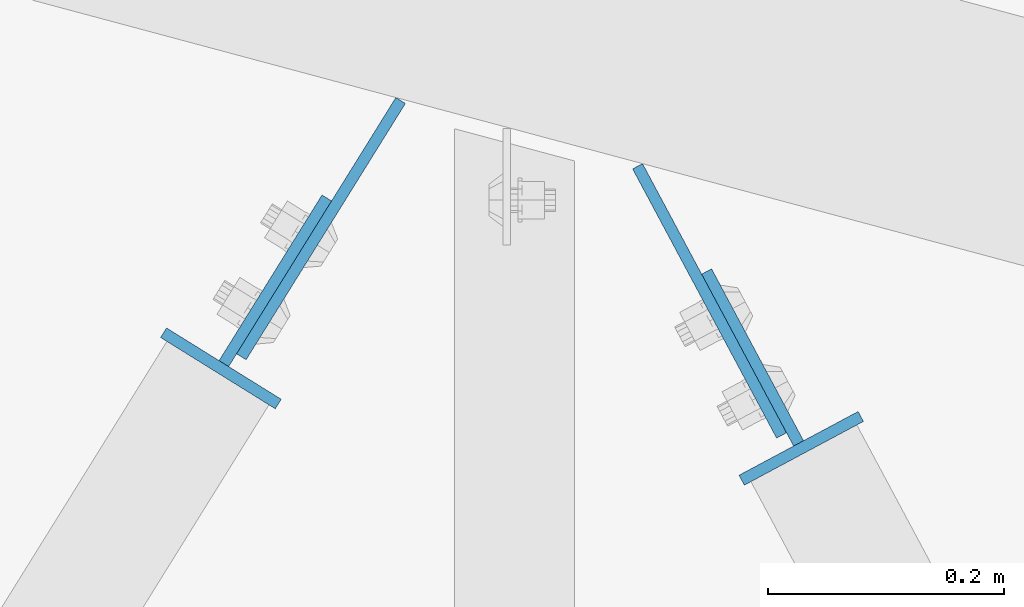
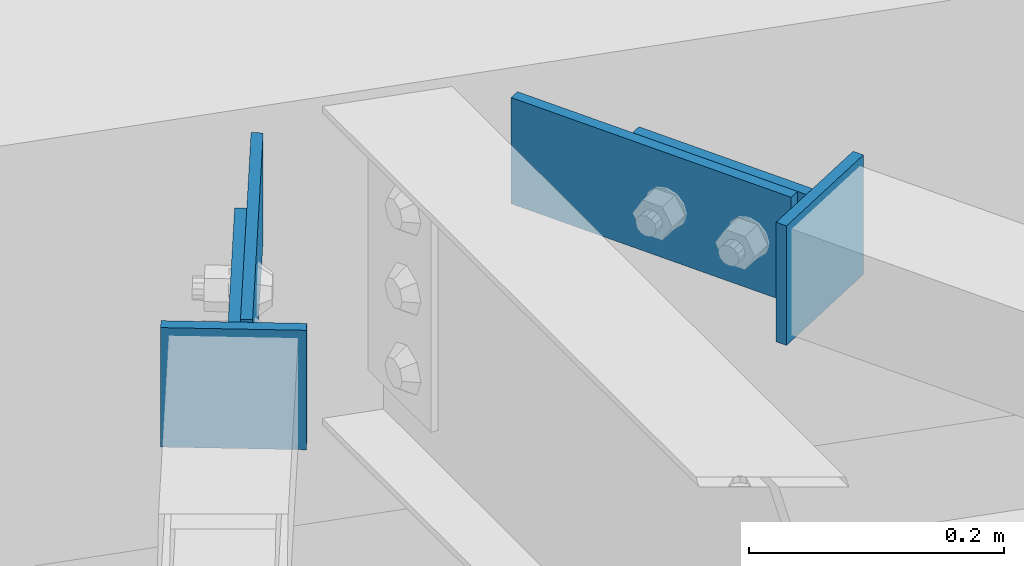
# One storey, part 965 of 1763: 6 columns, 3 elements without a shape of their own.
"""IFC2X3 building model written with IfcOpenShell, lengths in millimetres."""

from ifc_helpers import new_model, si_unit, frame, origin_with_axes, place, context, subcontext, project, spatial, faceted_brep, material, type_object, element, aggregate, save


model = new_model("IFC2X3")

# Units and contexts
model_context = context("Model", 3, precision=1e-05, world=origin_with_axes())
body_context = subcontext(model_context, "Body", "Model", "MODEL_VIEW")
ifc_project = project(units=[si_unit("LENGTHUNIT", "METRE", prefix="MILLI"), si_unit("AREAUNIT", "SQUARE_METRE"), si_unit("VOLUMEUNIT", "CUBIC_METRE"), si_unit("MASSUNIT", "GRAM", prefix="KILO"), si_unit("TIMEUNIT", "SECOND"), si_unit("PLANEANGLEUNIT", "RADIAN"), si_unit("SOLIDANGLEUNIT", "STERADIAN"), si_unit("THERMODYNAMICTEMPERATUREUNIT", "DEGREE_CELSIUS"), si_unit("LUMINOUSINTENSITYUNIT", "LUMEN")], contexts=[model_context])

# Site, building, storey
site_placement = place(None, origin_with_axes())
site = spatial("IfcSite", under=ifc_project, at=site_placement, CompositionType="ELEMENT")
building_placement = place(site_placement, origin_with_axes())
building = spatial("IfcBuilding", under=site, at=building_placement, Name="Undefined", CompositionType="ELEMENT")
storey_placement = place(building_placement, origin_with_axes())
storey = spatial("IfcBuildingStorey", under=building, at=storey_placement, Name="Undefined", CompositionType="ELEMENT", Elevation=0.0)

# Assembly, column
assembly_1_placement = place(storey_placement, origin_with_axes())
assembly_1 = element("IfcElementAssembly", 1, at=assembly_1_placement, inside=storey, Name="H. BRACE", AssemblyPlace="NOTDEFINED", PredefinedType="RIGID_FRAME")
ifc_material = material(Name="STEEL/A36")
column_type_1 = type_object("IfcColumnType", PredefinedType="NOTDEFINED")
column_1_placement = place(assembly_1_placement, frame((-35640.7635952353, 65227.07099366, 12428.5375), z_axis=(-0.849331705716084, 0.527859501823551, 0.0), x_axis=(0.0, 0.0, -1.0)))
column_1 = element("IfcColumn", 2, at=column_1_placement, type_object=column_type_1, material=ifc_material, Name="PLATE", context=body_context, shape_type="Brep", body=[
    faceted_brep([(0.0, 4.76249999989523, -57.1500000001702), (0.0, 4.76250000014261, 57.1500000001565), (114.299999999999, 4.76250000014261, 57.1500000001565), (114.299999999999, 4.76249999989523, -57.1500000001702), (0.0, -4.76249999988067, 57.1500000001784), (114.299999999999, -4.76249999988067, 57.1500000001784), (0.0, -4.76250000012806, -57.150000000152), (114.299999999999, -4.76250000012806, -57.150000000152)], [[[0, 1, 2, 3]], [[1, 4, 5, 2]], [[4, 6, 7, 5]], [[6, 0, 3, 7]], [[5, 7, 3, 2]], [[6, 4, 1, 0]]]),
])

assembly_2_placement = place(storey_placement, origin_with_axes())
assembly_2 = element("IfcElementAssembly", 3, at=assembly_2_placement, inside=storey, Name="H. BRACE", AssemblyPlace="NOTDEFINED", PredefinedType="RIGID_FRAME")
column_2_placement = place(assembly_2_placement, frame((-35149.6172623141, 65159.4000985593, 12428.5375), z_axis=(-0.881740062400724, -0.471735585214394, 0.0), x_axis=(0.0, 0.0, -1.0)))
column_2 = element("IfcColumn", 4, at=column_2_placement, type_object=column_type_1, material=ifc_material, Name="PLATE", context=body_context, shape_type="Brep", body=[
    faceted_brep([(0.0, 4.76249999989523, -57.1500000001702), (0.0, 4.76250000014261, 57.1500000001565), (114.299999999999, 4.76250000014261, 57.1500000001565), (114.299999999999, 4.76249999989523, -57.1500000001702), (0.0, -4.76249999988067, 57.1500000001784), (114.299999999999, -4.76249999988067, 57.1500000001784), (0.0, -4.76250000012806, -57.150000000152), (114.299999999999, -4.76250000012806, -57.150000000152)], [[[0, 1, 2, 3]], [[1, 4, 5, 2]], [[4, 6, 7, 5]], [[6, 0, 3, 7]], [[5, 7, 3, 2]], [[6, 4, 1, 0]]]),
])

assembly_3_placement = place(storey_placement, origin_with_axes())
assembly_3 = element("IfcElementAssembly", 5, at=assembly_3_placement, inside=storey, Name="BEAM", AssemblyPlace="NOTDEFINED", PredefinedType="RIGID_FRAME")
column_type_2 = type_object("IfcColumnType", PredefinedType="NOTDEFINED")
column_3_placement = place(assembly_3_placement, frame((-35556.0512090332, 65345.3295743099, 12422.1875), z_axis=(0.527859501823548, 0.849331705716086, 0.0), x_axis=(0.0, 0.0, -1.0)))
column_3 = element("IfcColumn", 6, at=column_3_placement, type_object=column_type_2, material=ifc_material, Name="PLATE", context=body_context, shape_type="Brep", body=[
    faceted_brep([(0.0, 4.76250000019354, -127.694499999889), (0.0, 4.76249999980791, 127.694499999903), (101.599999999999, 4.76249999980791, 127.694499999903), (101.599999999999, 4.76250000019354, -127.694499999889), (0.0, -4.76250000018626, 127.694499999881), (101.599999999999, -4.76250000018626, 127.694499999881), (0.0, -4.76249999979336, -127.69449999991), (101.599999999999, -4.76249999979336, -127.69449999991)], [[[0, 1, 2, 3]], [[1, 4, 5, 2]], [[4, 6, 7, 5]], [[6, 0, 3, 7]], [[5, 7, 3, 2]], [[6, 4, 1, 0]]]),
])

# Column
column_4_placement = place(assembly_1_placement, frame((-35594.6891146889, 65301.2053362591, 12422.1875), z_axis=(0.527859501823548, 0.849331705716086, 0.0), x_axis=(0.0, 0.0, -1.0)))
column_4 = element("IfcColumn", 7, at=column_4_placement, type_object=column_type_2, material=ifc_material, Name="PLATE", context=body_context, shape_type="Brep", body=[
    faceted_brep([(0.0, 4.76250000017899, -82.5230000001757), (0.0, 4.76249999980064, 82.5230000001757), (101.599999999999, 4.76249999980064, 82.5230000001757), (101.599999999999, 4.76250000017899, -82.5230000001757), (0.0, -4.7625000001899, 82.5230000001757), (101.599999999999, -4.7625000001899, 82.5230000001757), (0.0, -4.76249999981155, -82.5230000001684), (101.599999999999, -4.76249999981155, -82.5230000001684)], [[[0, 1, 2, 3]], [[1, 4, 5, 2]], [[4, 6, 7, 5]], [[6, 0, 3, 7]], [[5, 7, 3, 2]], [[6, 4, 1, 0]]]),
])

aggregate(assembly_1, [column_1, column_4])

column_5_placement = place(assembly_3_placement, frame((-35227.1937371705, 65284.2100294328, 12422.1875), z_axis=(-0.471735585214394, 0.881740062400724, 0.0), x_axis=(0.0, 0.0, -1.0)))
column_5 = element("IfcColumn", 8, at=column_5_placement, type_object=column_type_2, material=ifc_material, Name="PLATE", context=body_context, shape_type="Brep", body=[
    faceted_brep([(0.0, 4.76250000045081, -129.183000000063), (0.0, 4.76249999956678, 129.183000000136), (101.599999999999, 4.76249999956678, 129.183000000136), (101.599999999999, 4.76250000045081, -129.183000000063), (0.0, -4.76250000043831, 129.183000000092), (101.599999999999, -4.76250000043831, 129.183000000092), (0.0, -4.76249999955792, -129.183000000106), (101.599999999999, -4.76249999955792, -129.183000000106)], [[[0, 1, 2, 3]], [[1, 4, 5, 2]], [[4, 6, 7, 5]], [[6, 0, 3, 7]], [[5, 7, 3, 2]], [[6, 4, 1, 0]]]),
])

aggregate(assembly_3, [column_3, column_5])

column_6_placement = place(assembly_2_placement, frame((-35190.7825605542, 65236.3438224949, 12422.1875), z_axis=(-0.471735585214394, 0.881740062400724, 0.0), x_axis=(0.0, 0.0, -1.0)))
column_6 = element("IfcColumn", 9, at=column_6_placement, type_object=column_type_2, material=ifc_material, Name="PLATE", context=body_context, shape_type="Brep", body=[
    faceted_brep([(0.0, 4.76250000028733, -82.5010000000329), (0.0, 4.76249999973072, 82.5010000000912), (101.599999999999, 4.76249999973072, 82.5010000000912), (101.599999999999, 4.76250000028733, -82.5010000000329), (0.0, -4.76250000028165, 82.501000000062), (101.599999999999, -4.76250000028165, 82.501000000062), (0.0, -4.76249999972504, -82.501000000062), (101.599999999999, -4.76249999972504, -82.501000000062)], [[[0, 1, 2, 3]], [[1, 4, 5, 2]], [[4, 6, 7, 5]], [[6, 0, 3, 7]], [[5, 7, 3, 2]], [[6, 4, 1, 0]]]),
])

aggregate(assembly_2, [column_2, column_6])

save(model, "model.ifc")
